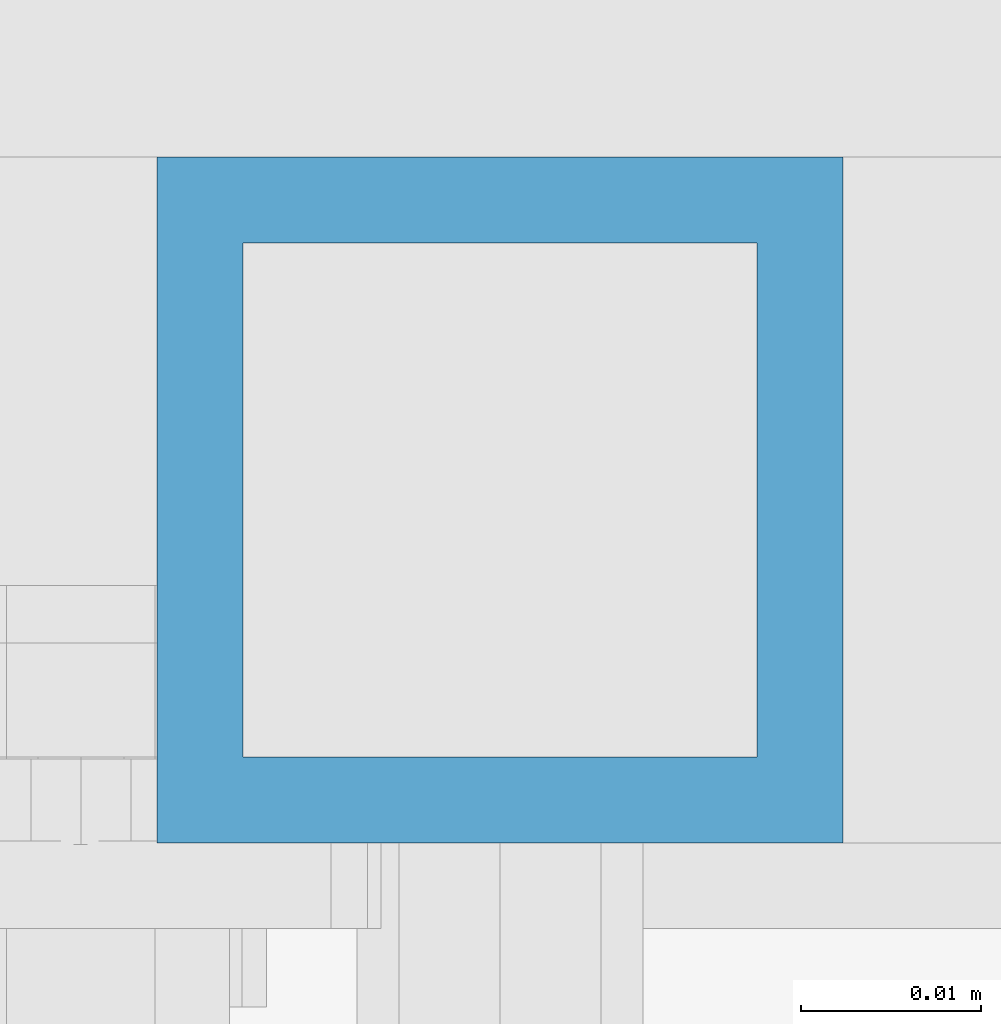
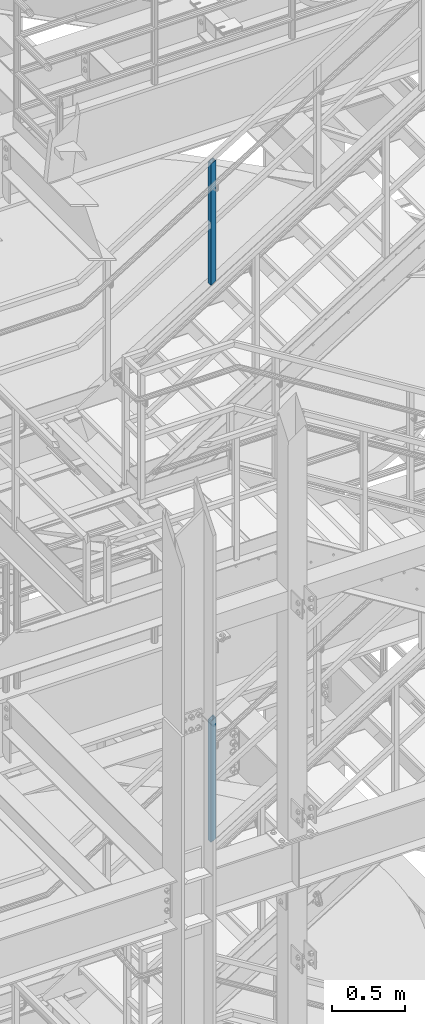
# One storey, part 617 of 1876: 2 columns, 2 elements without a shape of their own.
"""IFC2X3 building model written with IfcOpenShell, lengths in millimetres."""

from ifc_helpers import new_model, si_unit, frame, origin_with_axes, place, context, subcontext, project, spatial, faceted_brep, material, type_object, element, aggregate, save


model = new_model("IFC2X3")

# Units and contexts
model_context = context("Model", 3, precision=1e-05, world=origin_with_axes())
body_context = subcontext(model_context, "Body", "Model", "MODEL_VIEW")
ifc_project = project(units=[si_unit("LENGTHUNIT", "METRE", prefix="MILLI"), si_unit("AREAUNIT", "SQUARE_METRE"), si_unit("VOLUMEUNIT", "CUBIC_METRE"), si_unit("MASSUNIT", "GRAM", prefix="KILO"), si_unit("TIMEUNIT", "SECOND"), si_unit("PLANEANGLEUNIT", "RADIAN"), si_unit("SOLIDANGLEUNIT", "STERADIAN"), si_unit("THERMODYNAMICTEMPERATUREUNIT", "DEGREE_CELSIUS"), si_unit("LUMINOUSINTENSITYUNIT", "LUMEN")], contexts=[model_context])

# Site, building, storey
site_placement = place(None, origin_with_axes())
site = spatial("IfcSite", under=ifc_project, at=site_placement, CompositionType="ELEMENT")
building_placement = place(site_placement, origin_with_axes())
building = spatial("IfcBuilding", under=site, at=building_placement, Name="Undefined", CompositionType="ELEMENT")
storey_placement = place(building_placement, origin_with_axes())
storey = spatial("IfcBuildingStorey", under=building, at=storey_placement, Name="Undefined", CompositionType="ELEMENT", Elevation=0.0)

# Assembly, column
assembly_1_placement = place(storey_placement, origin_with_axes())
assembly_1 = element("IfcElementAssembly", 1, at=assembly_1_placement, inside=storey, Name="RAIL", AssemblyPlace="NOTDEFINED", PredefinedType="RIGID_FRAME")
ifc_material = material()
column_type = type_object("IfcColumnType", Name="HSS1-1/2X1-1/2X3/16", PredefinedType="NOTDEFINED")
column_1_placement = place(assembly_1_placement, frame((3252.25833356203, -4781.55000114554, 11599.6140691563), z_axis=(-1.0, 0.0, 0.0), x_axis=(0.0, 0.0, 1.0)))
column_1 = element("IfcColumn", 2, at=column_1_placement, type_object=column_type, material=ifc_material, Name="POST", ObjectType="HSS1-1/2X1-1/2X3/16", context=body_context, shape_type="Brep", body=[
    faceted_brep([(1026.33175871902, -19.0500000000002, -19.0499992350001), (1026.33175871902, 19.0499992349996, -19.0499992350001), (1002.89450115962, 19.0499992349996, 19.0499992349996), (1002.89450115962, -19.0499992349996, 19.0499992349996), (1023.40208377724, -14.2874994260001, -14.2874994260001), (1005.82416013402, -14.2874994260001, 14.2874994260001), (1005.82416013402, 14.2874994260001, 14.2874994260001), (1023.40208377724, 14.2874994260001, -14.2874994260001), (-11.7186358969739, 19.0499992349996, 19.0499992349996), (-11.7186358969739, -19.0499992349996, 19.0499992349996), (11.7186358969793, -19.0499992349996, -19.0499992349996), (11.7186358969793, 19.0499992349996, -19.0499992349996), (-8.78902482466219, 14.2874994260001, 14.2874994260001), (-8.78902482466219, -14.2874994260001, 14.2874994260001), (8.78902482575359, -14.2874994260001, -14.2874994260001), (8.78902482575359, 14.2874994260001, -14.2874994260001)], [[[0, 1, 2, 3], [4, 5, 6, 7]], [[8, 9, 3, 2]], [[9, 10, 0, 3]], [[10, 11, 1, 0]], [[11, 8, 2, 1]], [[10, 9, 8, 11], [12, 13, 14, 15]], [[15, 14, 4, 7]], [[12, 15, 7, 6]], [[13, 12, 6, 5]], [[14, 13, 5, 4]]]),
])
aggregate(assembly_1, [column_1])

assembly_2_placement = place(storey_placement, origin_with_axes())
assembly_2 = element("IfcElementAssembly", 3, at=assembly_2_placement, inside=storey, Name="RAIL", AssemblyPlace="NOTDEFINED", PredefinedType="RIGID_FRAME")
column_2_placement = place(assembly_2_placement, frame((3252.25833234056, -4781.55000114554, 16260.930442066), z_axis=(-1.0, 0.0, 0.0), x_axis=(0.0, 0.0, 1.0)))
column_2 = element("IfcColumn", 4, at=column_2_placement, type_object=column_type, material=ifc_material, Name="POST", ObjectType="HSS1-1/2X1-1/2X3/16", context=body_context, shape_type="Brep", body=[
    faceted_brep([(1026.31311450052, -19.0500000000002, -19.0499992349996), (1026.31311450052, 19.0499992349996, -19.0499992349996), (1002.71048974224, 19.0499992349996, 19.0499992349996), (1002.71048974224, -19.0499992349996, 19.0499992349996), (1023.36278640575, -14.2874994260001, -14.2874994260001), (1005.66081783739, -14.2874994260001, 14.2874994260001), (1005.66081783739, 14.2874994260001, 14.2874994260001), (1023.36278640575, 14.2874994260001, -14.2874994260001), (-11.8013123776254, 19.0499992349996, 19.0499992349996), (-11.8013123776254, -19.0499992349996, 19.0499992349996), (11.8013123805795, -19.0499992349996, -19.0499992349996), (11.8013123805795, 19.0499992349996, -19.0499992349996), (-8.85098428269339, 14.2874994260001, 14.2874994260001), (-8.85098428269339, -14.2874994260001, 14.2874994260001), (8.85098428565107, -14.2874994260001, -14.2874994260001), (8.85098428565107, 14.2874994260001, -14.2874994260001)], [[[0, 1, 2, 3], [4, 5, 6, 7]], [[8, 9, 3, 2]], [[9, 10, 0, 3]], [[10, 11, 1, 0]], [[11, 8, 2, 1]], [[10, 9, 8, 11], [12, 13, 14, 15]], [[15, 14, 4, 7]], [[12, 15, 7, 6]], [[13, 12, 6, 5]], [[14, 13, 5, 4]]]),
])
aggregate(assembly_2, [column_2])

save(model, "model.ifc")
